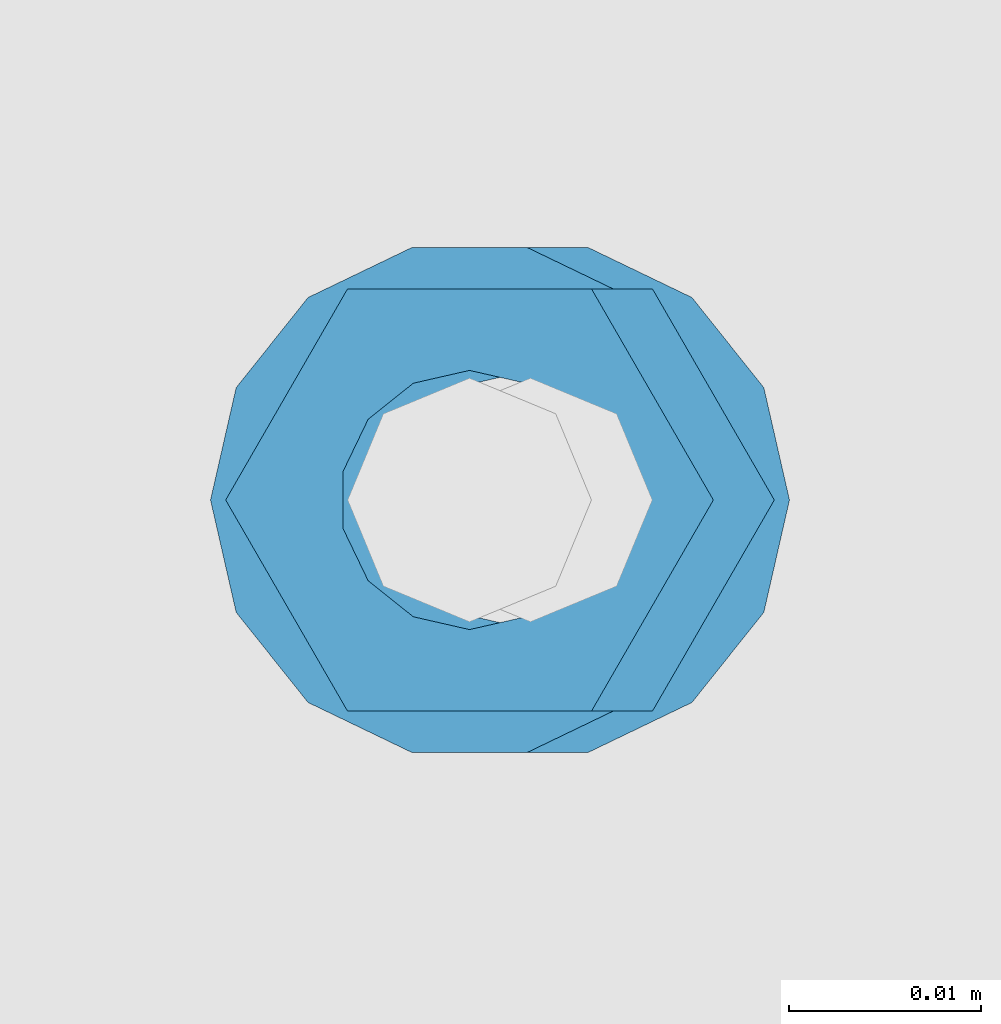
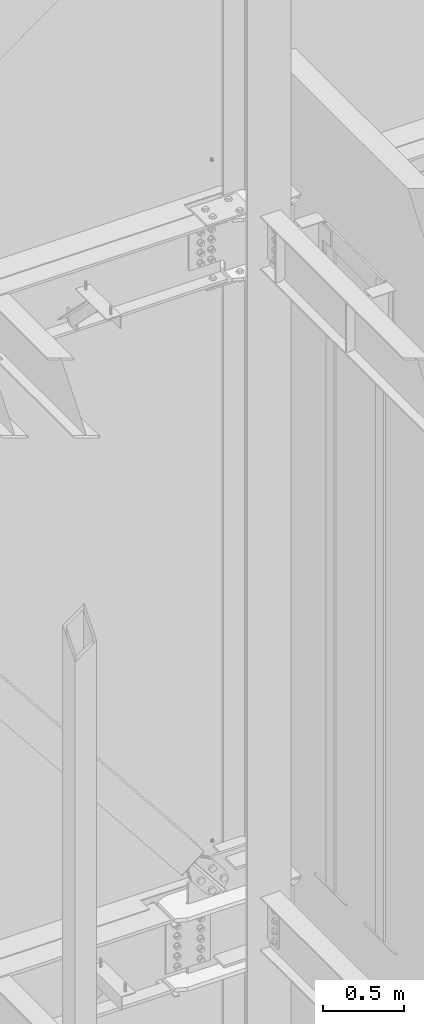
# One storey, part 691 of 1179: 4 columns, 2 elements without a shape of their own.
"""IFC2X3 building model written with IfcOpenShell, lengths in millimetres."""

import ifcopenshell
import ifcopenshell.guid

model = None  # the IFC model being written
_history = None  # IfcOwnerHistory: only IFC2X3 demands one
_inside = {}  # id of a spatial element -> (the spatial element, [elements in it])
_under = {}  # id of a project, library or spatial element -> (it, [spatial elements below it])
_declared = {}  # id of a project -> (the project, [libraries it declares])
_typed = {}  # id of a type object -> (the type object, [elements of that type])
_made_of = {}  # id of a material, layer set ... -> (it, [elements and type objects made of it])


def new_model(schema):
    """Start an empty IFC model of exactly this schema.

    Asked for "IFC4X3", IfcOpenShell would pick the latest addendum, in which some entities
    have other attributes; the version numbers below select the first issue.
    IFC2X3 requires an IfcOwnerHistory on every rooted entity: one is made here for all.
    """
    global model, _history
    if schema == "IFC4X3":
        model = ifcopenshell.file(schema_version=(4, 3, 0, 0))
    else:
        model = ifcopenshell.file(schema=schema)
    _inside.clear()
    _under.clear()
    _declared.clear()
    _typed.clear()
    _made_of.clear()
    _history = None
    if model.schema == "IFC2X3":
        org = make("IfcOrganization", Name="unknown")
        user = make(
            "IfcPersonAndOrganization",
            ThePerson=make("IfcPerson", FamilyName="unknown"),
            TheOrganization=org,
        )
        app = make(
            "IfcApplication",
            ApplicationDeveloper=org,
            Version="unknown",
            ApplicationFullName="unknown",
            ApplicationIdentifier="unknown",
        )
        _history = make(
            "IfcOwnerHistory",
            OwningUser=user,
            OwningApplication=app,
            ChangeAction="ADDED",
            CreationDate=0,
        )
    return model


def make(cls, **values):
    """One entity of the class cls with the attributes given. An attribute that is None is left unset."""
    return model.create_entity(
        cls, **{name: value for name, value in values.items() if value is not None}
    )


def rooted(cls, **values):
    """An entity with a GlobalId (a new one), such as an element, a storey or a relation."""
    return make(cls, GlobalId=ifcopenshell.guid.new(), OwnerHistory=_history, **values)


def si_unit(unit_type, name, prefix=None):
    """IfcSIUnit, for example si_unit("LENGTHUNIT", "METRE", prefix="MILLI")."""
    return make("IfcSIUnit", UnitType=unit_type, Prefix=prefix, Name=name)


def assignment(units):
    """IfcUnitAssignment: the units of a project."""
    return None if units is None else make("IfcUnitAssignment", Units=units)


def point(xyz):
    """IfcCartesianPoint."""
    return None if xyz is None else make("IfcCartesianPoint", Coordinates=xyz)


def direction(xyz):
    """IfcDirection."""
    return None if xyz is None else make("IfcDirection", DirectionRatios=xyz)


def frame(location, z_axis=None, x_axis=None):
    """IfcAxis2Placement3D, a coordinate frame: its origin and axes. An axis left out is left unset."""
    return make(
        "IfcAxis2Placement3D",
        Location=point(location),
        Axis=direction(z_axis),
        RefDirection=direction(x_axis),
    )


def origin_with_axes():
    """The frame at (0, 0, 0) with the z axis (0, 0, 1) and the x axis (1, 0, 0) written out."""
    return frame((0.0, 0.0, 0.0), z_axis=(0.0, 0.0, 1.0), x_axis=(1.0, 0.0, 0.0))


def place(relative_to, where):
    """IfcLocalPlacement: puts the frame where relative to a parent placement (None: the world)."""
    return make(
        "IfcLocalPlacement", PlacementRelTo=relative_to, RelativePlacement=where
    )


def context(
    kind, dimensions, precision=None, world=None, true_north=None, identifier=None
):
    """IfcGeometricRepresentationContext, for example the 3D "Model" context."""
    return make(
        "IfcGeometricRepresentationContext",
        ContextIdentifier=identifier,
        ContextType=kind,
        CoordinateSpaceDimension=dimensions,
        Precision=precision,
        WorldCoordinateSystem=world,
        TrueNorth=true_north,
    )


def subcontext(parent, identifier, kind, view, scale=None):
    """IfcGeometricRepresentationSubContext, for example "Body" below "Model"."""
    return make(
        "IfcGeometricRepresentationSubContext",
        ContextIdentifier=identifier,
        ContextType=kind,
        ParentContext=parent,
        TargetScale=scale,
        TargetView=view,
    )


def project(units=None, contexts=None):
    """IfcProject with its units and contexts."""
    return rooted(
        "IfcProject",
        Name="project",
        RepresentationContexts=contexts,
        UnitsInContext=assignment(units),
    )


def spatial(cls, under=None, at=None, **own):
    """A site, building, storey or space (cls), placed at a placement, below another one or the project."""
    s = rooted(cls, ObjectPlacement=at, **own)
    if under is not None:
        _under.setdefault(under.id(), (under, []))[1].append(s)
    return s


def faces_of(points, faces, orient=None, outer=None):
    """IfcFace entities. A face is a list of loops; a loop is a list of indices into points, from 0.

    orient and outer hold one flag for each loop. By default every Orientation is true, the
    first loop of a face is its IfcFaceOuterBound and the others are IfcFaceBound.
    """
    made = []
    for i, loops in enumerate(faces):
        bounds = []
        for j, loop in enumerate(loops):
            is_outer = j == 0 if outer is None else outer[i][j]
            bounds.append(
                make(
                    "IfcFaceOuterBound" if is_outer else "IfcFaceBound",
                    Bound=make("IfcPolyLoop", Polygon=[points[k] for k in loop]),
                    Orientation=True if orient is None else orient[i][j],
                )
            )
        made.append(make("IfcFace", Bounds=bounds))
    return made


def faceted_brep(points, faces, orient=None, outer=None, voids=None):
    """IfcFacetedBrep: a solid bounded by flat faces; with voids (closed shells), ...WithVoids."""
    shared = [point(p) for p in points]
    hull = make("IfcClosedShell", CfsFaces=faces_of(shared, faces, orient, outer))
    if voids is None:
        return make("IfcFacetedBrep", Outer=hull)
    return make(
        "IfcFacetedBrepWithVoids",
        Outer=hull,
        Voids=[
            make(cls, CfsFaces=faces_of(shared, fs, o, b)) for cls, fs, o, b in voids
        ],
    )


def shape(context_of_items, identifier, shape_type, items):
    """IfcShapeRepresentation: the items that make up one representation, for example the "Body"."""
    return make(
        "IfcShapeRepresentation",
        ContextOfItems=context_of_items,
        RepresentationIdentifier=identifier,
        RepresentationType=shape_type,
        Items=items,
    )


def material(Name=None, Category=None):
    """IfcMaterial."""
    return make("IfcMaterial", Name=Name, Category=Category)


def made_of(thing, what):
    """Note that an element or type object is made of a material, layer set ...; save() writes the relation."""
    if what is not None:
        _made_of.setdefault(what.id(), (what, []))[1].append(thing)
    return thing


def type_object(cls, material=None, **own):
    """A type object (cls), such as IfcWallType, which elements share."""
    return made_of(rooted(cls, **own), material)


def element(
    cls,
    number,
    at=None,
    inside=None,
    cuts=None,
    type_object=None,
    material=None,
    context=None,
    identifier="Body",
    shape_type=None,
    held_by="IfcProductDefinitionShape",
    body=None,
    shapes=None,
    **own,
):
    """One element of the class cls, such as IfcWall. Its Tag is "e" and its number.

    at: its placement. inside: the storey or other place that contains it. cuts: it is an
    opening in that element (IfcRelVoidsElement). A single representation is given by context,
    identifier, shape_type and body (its items); several are given by shapes. held_by: the class
    of the entity that holds the representations. save() writes the other relations.
    """
    e = rooted(cls, Tag="e%d" % number, ObjectPlacement=at, **own)
    if body is not None:
        shapes = [shape(context, identifier, shape_type, body)]
    if shapes is not None:
        e.Representation = make(held_by, Representations=shapes)
    if inside is not None:
        _inside.setdefault(inside.id(), (inside, []))[1].append(e)
    if cuts is not None:
        rooted(
            "IfcRelVoidsElement", RelatingBuildingElement=cuts, RelatedOpeningElement=e
        )
    if type_object is not None:
        _typed.setdefault(type_object.id(), (type_object, []))[1].append(e)
    return made_of(e, material)


def aggregate(whole, parts):
    """IfcRelAggregates: a whole, such as a stair, and the parts it consists of."""
    return rooted("IfcRelAggregates", RelatingObject=whole, RelatedObjects=parts)


def save(model, path):
    """Write the relations noted so far, then the file.

    IfcRelAggregates (storeys below a building ...), IfcRelContainedInSpatialStructure (elements
    in a storey), IfcRelDefinesByType, IfcRelAssociatesMaterial and IfcRelDeclares: one each for
    every whole, place, type object, material and project.
    """
    for whole, parts in _under.values():
        aggregate(whole, parts)
    for where, things in _inside.values():
        rooted(
            "IfcRelContainedInSpatialStructure",
            RelatedElements=things,
            RelatingStructure=where,
        )
    for kind, things in _typed.values():
        rooted("IfcRelDefinesByType", RelatedObjects=things, RelatingType=kind)
    for what, things in _made_of.values():
        rooted("IfcRelAssociatesMaterial", RelatedObjects=things, RelatingMaterial=what)
    for by, libraries in _declared.values():
        rooted("IfcRelDeclares", RelatingContext=by, RelatedDefinitions=libraries)
    model.write(path)


model = new_model("IFC2X3")

# Units and contexts
model_context = context("Model", 3, precision=1e-05, world=origin_with_axes())
body_context = subcontext(model_context, "Body", "Model", "MODEL_VIEW")
ifc_project = project(units=[si_unit("LENGTHUNIT", "METRE", prefix="MILLI"), si_unit("AREAUNIT", "SQUARE_METRE"), si_unit("VOLUMEUNIT", "CUBIC_METRE"), si_unit("MASSUNIT", "GRAM", prefix="KILO"), si_unit("TIMEUNIT", "SECOND"), si_unit("PLANEANGLEUNIT", "RADIAN"), si_unit("SOLIDANGLEUNIT", "STERADIAN"), si_unit("THERMODYNAMICTEMPERATUREUNIT", "DEGREE_CELSIUS"), si_unit("LUMINOUSINTENSITYUNIT", "LUMEN")], contexts=[model_context])

# Site, building, storey
site_placement = place(None, origin_with_axes())
site = spatial("IfcSite", under=ifc_project, at=site_placement, CompositionType="ELEMENT")
building_placement = place(site_placement, origin_with_axes())
building = spatial("IfcBuilding", under=site, at=building_placement, Name="Undefined", CompositionType="ELEMENT")
storey_placement = place(building_placement, origin_with_axes())
storey = spatial("IfcBuildingStorey", under=building, at=storey_placement, Name="Undefined", CompositionType="ELEMENT", Elevation=0.0)

# Assembly, column
assembly_1_placement = place(storey_placement, origin_with_axes())
assembly_1 = element("IfcElementAssembly", 1, at=assembly_1_placement, inside=storey, Name="BEAM", AssemblyPlace="NOTDEFINED", PredefinedType="RIGID_FRAME")
ifc_material = material(Name="STEEL/A307")
column_type_1 = type_object("IfcColumnType", Name="1/2_WASHER", PredefinedType="NOTDEFINED")
column_1_placement = place(assembly_1_placement, frame((16332.2, 41529.0, 13252.45), z_axis=(0.0, 1.0, 0.0), x_axis=(0.0, 0.0, 1.0)))
column_1 = element("IfcColumn", 2, at=column_1_placement, type_object=column_type_1, material=ifc_material, Name="WASHER", ObjectType="1/2_WASHER", context=body_context, shape_type="Brep", body=[
    faceted_brep([(0.0, -13.4899997711182, 0.0), (0.0, -12.1540698217868, -5.85309154138758), (4.76249999999891, -12.1540698217868, -5.85309154138758), (4.76249999999891, -13.4899997711182, 0.0), (0.0, -8.41087728436833, -10.5469065195466), (4.76249999999891, -8.41087728436833, -10.5469065195466), (0.0, -3.00180734814057, -13.1517773121896), (4.76249999999891, -3.00180734814057, -13.1517773121896), (0.0, 3.00180734814057, -13.1517773121896), (4.76249999999891, 3.00180734814057, -13.1517773121896), (0.0, 8.41087728436833, -10.5469065195466), (4.76249999999891, 8.41087728436833, -10.5469065195466), (0.0, 12.1540698217868, -5.85309154138758), (4.76249999999891, 12.1540698217868, -5.85309154138758), (0.0, 13.4899997711182, 0.0), (4.76249999999891, 13.4899997711182, 0.0), (0.0, 12.1540698217868, 5.85309154138758), (4.76249999999891, 12.1540698217868, 5.85309154138758), (0.0, 8.41087728436833, 10.5469065195466), (4.76249999999891, 8.41087728436833, 10.5469065195466), (0.0, 3.00180734814057, 13.1517773121896), (4.76249999999891, 3.00180734814057, 13.1517773121896), (0.0, -3.00180734814057, 13.1517773121896), (4.76249999999891, -3.00180734814057, 13.1517773121896), (0.0, -8.41087728436833, 10.5469065195466), (4.76249999999891, -8.41087728436833, 10.5469065195466), (0.0, -12.1540698217868, 5.85309154138758), (4.76249999999891, -12.1540698217868, 5.85309154138758), (0.0, 0.0, 6.75), (0.0, 2.9287152390425, 6.08153985834178), (4.76249999999891, 2.9287152390425, 6.08153985834178), (4.76249999999891, 0.0, 6.75), (0.0, 5.27736250665839, 4.2085561625463), (4.76249999999891, 5.27736250665839, 4.2085561625463), (0.0, 6.58076340722619, 1.50201630420543), (4.76249999999891, 6.58076340722619, 1.50201630420543), (0.0, 6.58076340722619, -1.50201630420543), (4.76249999999891, 6.58076340722619, -1.50201630420543), (0.0, 5.27736250665839, -4.2085561625463), (4.76249999999891, 5.27736250665839, -4.2085561625463), (0.0, 2.9287152390425, -6.08153985834088), (4.76249999999891, 2.9287152390425, -6.08153985834088), (0.0, 0.0, -6.75), (4.76249999999891, 0.0, -6.75), (0.0, -2.9287152390425, -6.08153985834178), (4.76249999999891, -2.9287152390425, -6.08153985834178), (0.0, -5.27736250665839, -4.2085561625463), (4.76249999999891, -5.27736250665839, -4.2085561625463), (0.0, -6.58076340722619, -1.50201630420543), (4.76249999999891, -6.58076340722619, -1.50201630420543), (0.0, -6.58076340722619, 1.50201630420543), (4.76249999999891, -6.58076340722619, 1.50201630420543), (0.0, -5.27736250665839, 4.2085561625463), (4.76249999999891, -5.27736250665839, 4.2085561625463), (0.0, -2.9287152390425, 6.08153985834088), (4.76249999999891, -2.9287152390425, 6.08153985834088)], [[[0, 1, 2, 3]], [[1, 4, 5, 2]], [[4, 6, 7, 5]], [[6, 8, 9, 7]], [[8, 10, 11, 9]], [[10, 12, 13, 11]], [[12, 14, 15, 13]], [[14, 16, 17, 15]], [[16, 18, 19, 17]], [[18, 20, 21, 19]], [[20, 22, 23, 21]], [[22, 24, 25, 23]], [[24, 26, 27, 25]], [[26, 0, 3, 27]], [[28, 29, 30, 31]], [[29, 32, 33, 30]], [[32, 34, 35, 33]], [[34, 36, 37, 35]], [[36, 38, 39, 37]], [[38, 40, 41, 39]], [[40, 42, 43, 41]], [[42, 44, 45, 43]], [[44, 46, 47, 45]], [[46, 48, 49, 47]], [[48, 50, 51, 49]], [[50, 52, 53, 51]], [[52, 54, 55, 53]], [[54, 28, 31, 55]], [[5, 7, 9, 11, 13, 15, 17, 19, 21, 23, 25, 27, 3, 2], [33, 35, 37, 39, 41, 43, 45, 47, 49, 51, 53, 55, 31, 30]], [[26, 24, 22, 20, 18, 16, 14, 12, 10, 8, 6, 4, 1, 0], [54, 52, 50, 48, 46, 44, 42, 40, 38, 36, 34, 32, 29, 28]]]),
])

assembly_2_placement = place(storey_placement, origin_with_axes())
assembly_2 = element("IfcElementAssembly", 3, at=assembly_2_placement, inside=storey, Name="BEAM", AssemblyPlace="NOTDEFINED", PredefinedType="RIGID_FRAME")
column_2_placement = place(assembly_2_placement, frame((16335.375, 41529.0, 8147.05), z_axis=(0.0, 1.0, 0.0), x_axis=(0.0, 0.0, 1.0)))
column_2 = element("IfcColumn", 4, at=column_2_placement, type_object=column_type_1, material=ifc_material, Name="WASHER", ObjectType="1/2_WASHER", context=body_context, shape_type="Brep", body=[
    faceted_brep([(0.0, -13.4899997711182, 0.0), (0.0, -12.1540698217868, -5.85309154138758), (4.76249999999891, -12.1540698217868, -5.85309154138758), (4.76249999999891, -13.4899997711182, 0.0), (0.0, -8.41087728436833, -10.5469065195466), (4.76249999999891, -8.41087728436833, -10.5469065195466), (0.0, -3.00180734814057, -13.1517773121896), (4.76249999999891, -3.00180734814057, -13.1517773121896), (0.0, 3.00180734814057, -13.1517773121896), (4.76249999999891, 3.00180734814057, -13.1517773121896), (0.0, 8.41087728436833, -10.5469065195466), (4.76249999999891, 8.41087728436833, -10.5469065195466), (0.0, 12.1540698217868, -5.85309154138758), (4.76249999999891, 12.1540698217868, -5.85309154138758), (0.0, 13.4899997711182, 0.0), (4.76249999999891, 13.4899997711182, 0.0), (0.0, 12.1540698217868, 5.85309154138758), (4.76249999999891, 12.1540698217868, 5.85309154138758), (0.0, 8.41087728436833, 10.5469065195466), (4.76249999999891, 8.41087728436833, 10.5469065195466), (0.0, 3.00180734814057, 13.1517773121896), (4.76249999999891, 3.00180734814057, 13.1517773121896), (0.0, -3.00180734814057, 13.1517773121896), (4.76249999999891, -3.00180734814057, 13.1517773121896), (0.0, -8.41087728436833, 10.5469065195466), (4.76249999999891, -8.41087728436833, 10.5469065195466), (0.0, -12.1540698217868, 5.85309154138758), (4.76249999999891, -12.1540698217868, 5.85309154138758), (0.0, 0.0, 6.75), (0.0, 2.9287152390425, 6.08153985834178), (4.76249999999891, 2.9287152390425, 6.08153985834178), (4.76249999999891, 0.0, 6.75), (0.0, 5.27736250665839, 4.2085561625463), (4.76249999999891, 5.27736250665839, 4.2085561625463), (0.0, 6.58076340722619, 1.50201630420543), (4.76249999999891, 6.58076340722619, 1.50201630420543), (0.0, 6.58076340722619, -1.50201630420543), (4.76249999999891, 6.58076340722619, -1.50201630420543), (0.0, 5.27736250665839, -4.2085561625463), (4.76249999999891, 5.27736250665839, -4.2085561625463), (0.0, 2.9287152390425, -6.08153985834088), (4.76249999999891, 2.9287152390425, -6.08153985834088), (0.0, 0.0, -6.75), (4.76249999999891, 0.0, -6.75), (0.0, -2.9287152390425, -6.08153985834178), (4.76249999999891, -2.9287152390425, -6.08153985834178), (0.0, -5.27736250665839, -4.2085561625463), (4.76249999999891, -5.27736250665839, -4.2085561625463), (0.0, -6.58076340722619, -1.50201630420543), (4.76249999999891, -6.58076340722619, -1.50201630420543), (0.0, -6.58076340722619, 1.50201630420543), (4.76249999999891, -6.58076340722619, 1.50201630420543), (0.0, -5.27736250665839, 4.2085561625463), (4.76249999999891, -5.27736250665839, 4.2085561625463), (0.0, -2.9287152390425, 6.08153985834088), (4.76249999999891, -2.9287152390425, 6.08153985834088)], [[[0, 1, 2, 3]], [[1, 4, 5, 2]], [[4, 6, 7, 5]], [[6, 8, 9, 7]], [[8, 10, 11, 9]], [[10, 12, 13, 11]], [[12, 14, 15, 13]], [[14, 16, 17, 15]], [[16, 18, 19, 17]], [[18, 20, 21, 19]], [[20, 22, 23, 21]], [[22, 24, 25, 23]], [[24, 26, 27, 25]], [[26, 0, 3, 27]], [[28, 29, 30, 31]], [[29, 32, 33, 30]], [[32, 34, 35, 33]], [[34, 36, 37, 35]], [[36, 38, 39, 37]], [[38, 40, 41, 39]], [[40, 42, 43, 41]], [[42, 44, 45, 43]], [[44, 46, 47, 45]], [[46, 48, 49, 47]], [[48, 50, 51, 49]], [[50, 52, 53, 51]], [[52, 54, 55, 53]], [[54, 28, 31, 55]], [[5, 7, 9, 11, 13, 15, 17, 19, 21, 23, 25, 27, 3, 2], [33, 35, 37, 39, 41, 43, 45, 47, 49, 51, 53, 55, 31, 30]], [[26, 24, 22, 20, 18, 16, 14, 12, 10, 8, 6, 4, 1, 0], [54, 52, 50, 48, 46, 44, 42, 40, 38, 36, 34, 32, 29, 28]]]),
])

# Column
column_type_2 = type_object("IfcColumnType", Name="1/2_HEAVY_HEX_NUT", PredefinedType="NOTDEFINED")
column_3_placement = place(assembly_1_placement, frame((16332.2, 41529.0, 13257.2125), z_axis=(0.0, 1.0, 0.0), x_axis=(0.0, 0.0, 1.0)))
column_3 = element("IfcColumn", 5, at=column_3_placement, type_object=column_type_2, material=ifc_material, Name="NUT", ObjectType="1/2_HEAVY_HEX_NUT", context=body_context, shape_type="Brep", body=[
    faceted_brep([(0.0, -12.7, 0.0), (0.0, -6.34999990463257, -11.0), (12.7000000000007, -6.34999990463257, -11.0), (12.7000000000007, -12.6999998092651, 0.0), (0.0, 6.34999990463257, -11.0), (12.7000000000007, 6.34999990463257, -11.0), (0.0, 12.7, 0.0), (12.7000000000007, 12.6999998092651, 0.0), (0.0, 6.34999990463257, 11.0), (12.7000000000007, 6.34999990463257, 11.0), (0.0, -6.34999990463257, 11.0), (12.7000000000007, -6.34999990463257, 11.0), (0.0, 0.0, 6.75), (0.0, 2.9287152390425, 6.08153985834178), (12.7000000000007, 2.9287152390425, 6.08153985834178), (12.7000000000007, 0.0, 6.75), (0.0, 5.27736250665839, 4.2085561625463), (12.7000000000007, 5.27736250665839, 4.2085561625463), (0.0, 6.58076340722619, 1.50201630420543), (12.7000000000007, 6.58076340722619, 1.50201630420543), (0.0, 6.58076340722619, -1.50201630420543), (12.7000000000007, 6.58076340722619, -1.50201630420543), (0.0, 5.27736250665839, -4.2085561625463), (12.7000000000007, 5.27736250665839, -4.2085561625463), (0.0, 2.9287152390425, -6.08153985834088), (12.7000000000007, 2.9287152390425, -6.08153985834088), (0.0, 0.0, -6.75), (12.7000000000007, 0.0, -6.75), (0.0, -2.9287152390425, -6.08153985834178), (12.7000000000007, -2.9287152390425, -6.08153985834178), (0.0, -5.27736250665839, -4.2085561625463), (12.7000000000007, -5.27736250665839, -4.2085561625463), (0.0, -6.58076340722619, -1.50201630420543), (12.7000000000007, -6.58076340722619, -1.50201630420543), (0.0, -6.58076340722619, 1.50201630420543), (12.7000000000007, -6.58076340722619, 1.50201630420543), (0.0, -5.27736250665839, 4.2085561625463), (12.7000000000007, -5.27736250665839, 4.2085561625463), (0.0, -2.9287152390425, 6.08153985834088), (12.7000000000007, -2.9287152390425, 6.08153985834088)], [[[0, 1, 2, 3]], [[1, 4, 5, 2]], [[4, 6, 7, 5]], [[6, 8, 9, 7]], [[8, 10, 11, 9]], [[10, 0, 3, 11]], [[12, 13, 14, 15]], [[13, 16, 17, 14]], [[16, 18, 19, 17]], [[18, 20, 21, 19]], [[20, 22, 23, 21]], [[22, 24, 25, 23]], [[24, 26, 27, 25]], [[26, 28, 29, 27]], [[28, 30, 31, 29]], [[30, 32, 33, 31]], [[32, 34, 35, 33]], [[34, 36, 37, 35]], [[36, 38, 39, 37]], [[38, 12, 15, 39]], [[5, 7, 9, 11, 3, 2], [17, 19, 21, 23, 25, 27, 29, 31, 33, 35, 37, 39, 15, 14]], [[10, 8, 6, 4, 1, 0], [38, 36, 34, 32, 30, 28, 26, 24, 22, 20, 18, 16, 13, 12]]]),
])

aggregate(assembly_1, [column_1, column_3])

column_4_placement = place(assembly_2_placement, frame((16335.375, 41529.0, 8151.8125), z_axis=(0.0, 1.0, 0.0), x_axis=(0.0, 0.0, 1.0)))
column_4 = element("IfcColumn", 6, at=column_4_placement, type_object=column_type_2, material=ifc_material, Name="NUT", ObjectType="1/2_HEAVY_HEX_NUT", context=body_context, shape_type="Brep", body=[
    faceted_brep([(0.0, -12.7, 0.0), (0.0, -6.34999990463257, -11.0), (12.7000000000007, -6.34999990463257, -11.0), (12.7000000000007, -12.6999998092651, 0.0), (0.0, 6.34999990463257, -11.0), (12.7000000000007, 6.34999990463257, -11.0), (0.0, 12.7, 0.0), (12.7000000000007, 12.6999998092651, 0.0), (0.0, 6.34999990463257, 11.0), (12.7000000000007, 6.34999990463257, 11.0), (0.0, -6.34999990463257, 11.0), (12.7000000000007, -6.34999990463257, 11.0), (0.0, 0.0, 6.75), (0.0, 2.9287152390425, 6.08153985834178), (12.7000000000007, 2.9287152390425, 6.08153985834178), (12.7000000000007, 0.0, 6.75), (0.0, 5.27736250665839, 4.2085561625463), (12.7000000000007, 5.27736250665839, 4.2085561625463), (0.0, 6.58076340722619, 1.50201630420543), (12.7000000000007, 6.58076340722619, 1.50201630420543), (0.0, 6.58076340722619, -1.50201630420543), (12.7000000000007, 6.58076340722619, -1.50201630420543), (0.0, 5.27736250665839, -4.2085561625463), (12.7000000000007, 5.27736250665839, -4.2085561625463), (0.0, 2.9287152390425, -6.08153985834088), (12.7000000000007, 2.9287152390425, -6.08153985834088), (0.0, 0.0, -6.75), (12.7000000000007, 0.0, -6.75), (0.0, -2.9287152390425, -6.08153985834178), (12.7000000000007, -2.9287152390425, -6.08153985834178), (0.0, -5.27736250665839, -4.2085561625463), (12.7000000000007, -5.27736250665839, -4.2085561625463), (0.0, -6.58076340722619, -1.50201630420543), (12.7000000000007, -6.58076340722619, -1.50201630420543), (0.0, -6.58076340722619, 1.50201630420543), (12.7000000000007, -6.58076340722619, 1.50201630420543), (0.0, -5.27736250665839, 4.2085561625463), (12.7000000000007, -5.27736250665839, 4.2085561625463), (0.0, -2.9287152390425, 6.08153985834088), (12.7000000000007, -2.9287152390425, 6.08153985834088)], [[[0, 1, 2, 3]], [[1, 4, 5, 2]], [[4, 6, 7, 5]], [[6, 8, 9, 7]], [[8, 10, 11, 9]], [[10, 0, 3, 11]], [[12, 13, 14, 15]], [[13, 16, 17, 14]], [[16, 18, 19, 17]], [[18, 20, 21, 19]], [[20, 22, 23, 21]], [[22, 24, 25, 23]], [[24, 26, 27, 25]], [[26, 28, 29, 27]], [[28, 30, 31, 29]], [[30, 32, 33, 31]], [[32, 34, 35, 33]], [[34, 36, 37, 35]], [[36, 38, 39, 37]], [[38, 12, 15, 39]], [[5, 7, 9, 11, 3, 2], [17, 19, 21, 23, 25, 27, 29, 31, 33, 35, 37, 39, 15, 14]], [[10, 8, 6, 4, 1, 0], [38, 36, 34, 32, 30, 28, 26, 24, 22, 20, 18, 16, 13, 12]]]),
])

aggregate(assembly_2, [column_2, column_4])

save(model, "model.ifc")
